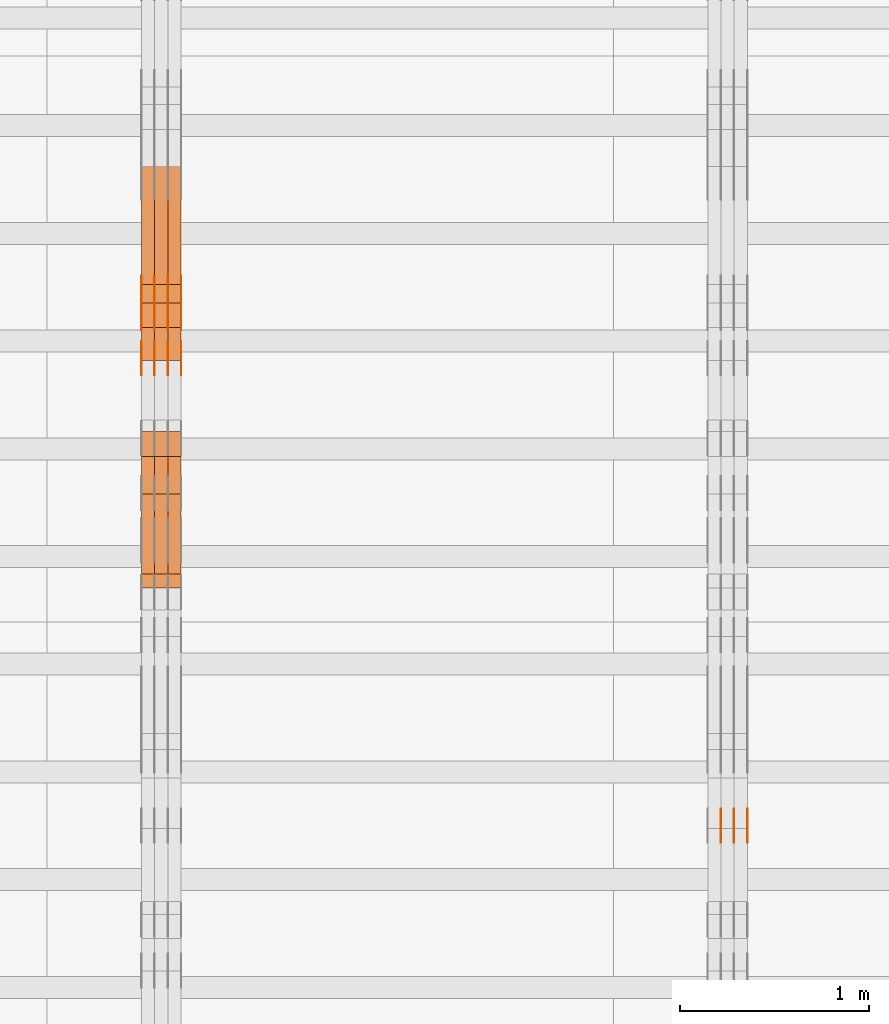
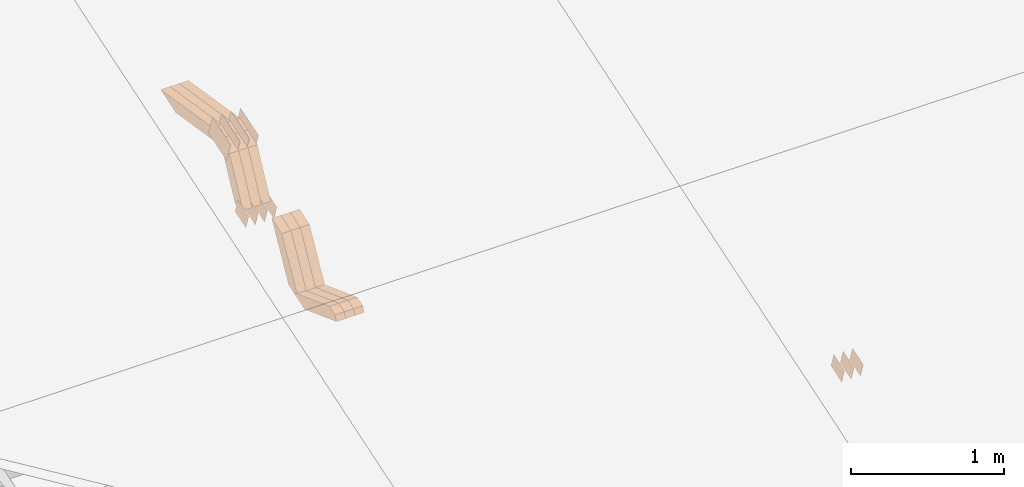
# One storey, part 66 of 385: 28 proxies.
"""IFC2X3 building model written with IfcOpenShell, lengths in millimetres."""

from ifc_helpers import new_model, entity, si_unit, converted_unit, derived_unit, direction, frame, origin, place, context, subcontext, project, spatial, polyline, outline, extrude, source, transform, mapped, material, type_object, type_shapes, element, save


model = new_model("IFC2X3")

# Units and contexts
model_context = context("Model", 3, precision=0.01, world=origin(), true_north=direction((6.12303176911189e-17, 1.0)))
body_context = subcontext(model_context, "Body", "Model", "MODEL_VIEW")
ifc_project = project(units=[si_unit("LENGTHUNIT", "METRE", prefix="MILLI"), si_unit("AREAUNIT", "SQUARE_METRE"), si_unit("VOLUMEUNIT", "CUBIC_METRE"), converted_unit("PLANEANGLEUNIT", "DEGREE", entity("IfcRatioMeasure", 0.0174532925199433), si_unit("PLANEANGLEUNIT", "RADIAN"), dimensions=[0, 0, 0, 0, 0, 0, 0]), si_unit("MASSUNIT", "GRAM", prefix="KILO"), derived_unit("MASSDENSITYUNIT", [(si_unit("MASSUNIT", "GRAM", prefix="KILO"), 1), (si_unit("LENGTHUNIT", "METRE"), -3)]), si_unit("TIMEUNIT", "SECOND"), si_unit("FREQUENCYUNIT", "HERTZ"), si_unit("THERMODYNAMICTEMPERATUREUNIT", "DEGREE_CELSIUS"), derived_unit("THERMALTRANSMITTANCEUNIT", [(si_unit("MASSUNIT", "GRAM", prefix="KILO"), 1), (si_unit("THERMODYNAMICTEMPERATUREUNIT", "KELVIN"), -1), (si_unit("TIMEUNIT", "SECOND"), -3)]), derived_unit("VOLUMETRICFLOWRATEUNIT", [(si_unit("LENGTHUNIT", "METRE"), 3), (si_unit("TIMEUNIT", "SECOND"), -1)]), si_unit("ELECTRICCURRENTUNIT", "AMPERE"), si_unit("ELECTRICVOLTAGEUNIT", "VOLT"), si_unit("POWERUNIT", "WATT"), si_unit("FORCEUNIT", "NEWTON", prefix="KILO"), si_unit("ILLUMINANCEUNIT", "LUX"), si_unit("LUMINOUSFLUXUNIT", "LUMEN"), si_unit("LUMINOUSINTENSITYUNIT", "CANDELA"), derived_unit("USERDEFINED", [(si_unit("MASSUNIT", "GRAM", prefix="KILO"), -1), (si_unit("LENGTHUNIT", "METRE"), -2), (si_unit("TIMEUNIT", "SECOND"), 3), (si_unit("LUMINOUSFLUXUNIT", "LUMEN"), 1)]), derived_unit("LINEARVELOCITYUNIT", [(si_unit("LENGTHUNIT", "METRE"), 1), (si_unit("TIMEUNIT", "SECOND"), -1)]), si_unit("PRESSUREUNIT", "PASCAL"), derived_unit("USERDEFINED", [(si_unit("LENGTHUNIT", "METRE"), -2), (si_unit("MASSUNIT", "GRAM", prefix="KILO"), 1), (si_unit("TIMEUNIT", "SECOND"), -2)])], contexts=[model_context])

# Site, building, storey
site_placement = place(None, origin())
site = spatial("IfcSite", under=ifc_project, at=site_placement, CompositionType="ELEMENT")
building_placement = place(site_placement, origin())
building = spatial("IfcBuilding", under=site, at=building_placement, CompositionType="ELEMENT")
storey_placement = place(building_placement, origin())
storey = spatial("IfcBuildingStorey", under=building, at=storey_placement, Name="Default", CompositionType="ELEMENT", Elevation=0.0)

# Proxies
ifc_material_1 = material(Name="IfcSurfaceStyle #173340")
building_element_proxy_type_1 = type_object("IfcBuildingElementProxyType", PredefinedType="NOTDEFINED", material=ifc_material_1)
shared_shape_1 = source(origin(), body_context, "Body", "SweptSolid", [
    extrude(outline(polyline([(-74.9998565677169, -60.0000596852269), (74.9998794200137, -60.0000596852269), (74.9998565677151, 60.0000596852269), (-74.9998794200119, 60.0000596852269), (-74.9998565677169, -60.0000596852269)])), frame((74.9998794200137, 60.0000596852269, 0.0), z_axis=(0.0, 0.0, 1.0), x_axis=(-1.0, 0.0, 0.0)), (0.0, 0.0, 1.0), 1.3),
])
type_shapes(building_element_proxy_type_1, [shared_shape_1])
proxy_1_placement = place(building_placement, frame((12386.3, 7527.6269081625, 1621.97418552253), z_axis=(-1.0, 0.0, 0.0), x_axis=(0.0, 0.951056516295124, 0.309016994375039)))
element("IfcBuildingElementProxy", 1, at=proxy_1_placement, inside=storey, type_object=building_element_proxy_type_1, material=ifc_material_1, context=body_context, shape_type="MappedRepresentation", body=[
    mapped(shared_shape_1, transform((0.0, 0.0, 0.0), scale=1.0)),
])
ifc_material_2 = material(Name="IfcSurfaceStyle #173283")
building_element_proxy_type_2 = type_object("IfcBuildingElementProxyType", PredefinedType="NOTDEFINED", material=ifc_material_2)
shared_shape_2 = source(origin(), body_context, "Body", "SweptSolid", [
    extrude(outline(polyline([(-74.9998565677169, -60.0000596852269), (74.9998794200137, -60.0000596852269), (74.9998565677151, 60.0000596852269), (-74.9998794200119, 60.0000596852269), (-74.9998565677169, -60.0000596852269)])), frame((74.9998794200137, 60.0000596852269, 0.0), z_axis=(0.0, 0.0, 1.0), x_axis=(-1.0, 0.0, 0.0)), (0.0, 0.0, 1.0), 1.3),
])
type_shapes(building_element_proxy_type_2, [shared_shape_2])
proxy_2_placement = place(building_placement, frame((12315.0, 7527.6269081625, 1621.97418552253), z_axis=(-1.0, 0.0, 0.0), x_axis=(0.0, 0.951056516295124, 0.309016994375039)))
element("IfcBuildingElementProxy", 2, at=proxy_2_placement, inside=storey, type_object=building_element_proxy_type_2, material=ifc_material_2, context=body_context, shape_type="MappedRepresentation", body=[
    mapped(shared_shape_2, transform((0.0, 0.0, 0.0), scale=1.0)),
])
ifc_material_3 = material(Name="IfcSurfaceStyle #173226")
building_element_proxy_type_3 = type_object("IfcBuildingElementProxyType", PredefinedType="NOTDEFINED", material=ifc_material_3)
shared_shape_3 = source(origin(), body_context, "Body", "SweptSolid", [
    extrude(outline(polyline([(-74.9998565677169, -60.0000596852269), (74.9998794200137, -60.0000596852269), (74.9998565677151, 60.0000596852269), (-74.9998794200119, 60.0000596852269), (-74.9998565677169, -60.0000596852269)])), frame((74.9998794200137, 60.0000596852269, 0.0), z_axis=(0.0, 0.0, 1.0), x_axis=(-1.0, 0.0, 0.0)), (0.0, 0.0, 1.0), 1.3),
])
type_shapes(building_element_proxy_type_3, [shared_shape_3])
proxy_3_placement = place(building_placement, frame((12316.3, 7527.6269081625, 1621.97418552253), z_axis=(-1.0, 0.0, 0.0), x_axis=(0.0, 0.951056516295124, 0.309016994375039)))
element("IfcBuildingElementProxy", 3, at=proxy_3_placement, inside=storey, type_object=building_element_proxy_type_3, material=ifc_material_3, context=body_context, shape_type="MappedRepresentation", body=[
    mapped(shared_shape_3, transform((0.0, 0.0, 0.0), scale=1.0)),
])
ifc_material_4 = material(Name="IfcSurfaceStyle #173169")
building_element_proxy_type_4 = type_object("IfcBuildingElementProxyType", PredefinedType="NOTDEFINED", material=ifc_material_4)
shared_shape_4 = source(origin(), body_context, "Body", "SweptSolid", [
    extrude(outline(polyline([(-74.9998565677169, -60.0000596852269), (74.9998794200137, -60.0000596852269), (74.9998565677151, 60.0000596852269), (-74.9998794200119, 60.0000596852269), (-74.9998565677169, -60.0000596852269)])), frame((74.9998794200137, 60.0000596852269, 0.0), z_axis=(0.0, 0.0, 1.0), x_axis=(-1.0, 0.0, 0.0)), (0.0, 0.0, 1.0), 1.29999999999999),
])
type_shapes(building_element_proxy_type_4, [shared_shape_4])
proxy_4_placement = place(building_placement, frame((12245.0, 7527.6269081625, 1621.97418552253), z_axis=(-1.0, 0.0, 0.0), x_axis=(0.0, 0.951056516295124, 0.309016994375039)))
element("IfcBuildingElementProxy", 4, at=proxy_4_placement, inside=storey, type_object=building_element_proxy_type_4, material=ifc_material_4, context=body_context, shape_type="MappedRepresentation", body=[
    mapped(shared_shape_4, transform((0.0, 0.0, 0.0), scale=1.0)),
])
ifc_material_5 = material(Name="IfcSurfaceStyle #140960")
building_element_proxy_type_5 = type_object("IfcBuildingElementProxyType", PredefinedType="NOTDEFINED", material=ifc_material_5)
shared_shape_5 = source(origin(), body_context, "Body", "SweptSolid", [
    extrude(outline(polyline([(-124.999432723313, -83.9999457831645), (125.000177551971, -83.9999457831645), (124.999395001513, 83.9999457831646), (-125.000139830171, 83.9999457831645), (-124.999432723313, -83.9999457831645)])), frame((125.000177551971, 84.0001194377192, 0.0), z_axis=(0.0, 0.0, 1.0), x_axis=(-1.0, 0.0, 0.0)), (0.0, 0.0, 1.0), 1.3),
])
type_shapes(building_element_proxy_type_5, [shared_shape_5])
proxy_5_placement = place(building_placement, frame((9386.29999999998, 10242.0968435407, 2855.88278137571), z_axis=(-1.0, 0.0, 0.0), x_axis=(0.0, 0.951056516295154, 0.309016994374948)))
element("IfcBuildingElementProxy", 5, at=proxy_5_placement, inside=storey, type_object=building_element_proxy_type_5, material=ifc_material_5, context=body_context, shape_type="MappedRepresentation", body=[
    mapped(shared_shape_5, transform((0.0, 0.0, 0.0), scale=1.0)),
])
ifc_material_6 = material(Name="IfcSurfaceStyle #140903")
building_element_proxy_type_6 = type_object("IfcBuildingElementProxyType", PredefinedType="NOTDEFINED", material=ifc_material_6)
shared_shape_6 = source(origin(), body_context, "Body", "SweptSolid", [
    extrude(outline(polyline([(-124.999432723313, -83.9999457831645), (125.000177551971, -83.9999457831645), (124.999395001513, 83.9999457831646), (-125.000139830171, 83.9999457831645), (-124.999432723313, -83.9999457831645)])), frame((125.000177551971, 84.0001194377192, 0.0), z_axis=(0.0, 0.0, 1.0), x_axis=(-1.0, 0.0, 0.0)), (0.0, 0.0, 1.0), 1.3),
])
type_shapes(building_element_proxy_type_6, [shared_shape_6])
proxy_6_placement = place(building_placement, frame((9315.0, 10242.0968435407, 2855.88278137571), z_axis=(-1.0, 0.0, 0.0), x_axis=(0.0, 0.951056516295154, 0.309016994374948)))
element("IfcBuildingElementProxy", 6, at=proxy_6_placement, inside=storey, type_object=building_element_proxy_type_6, material=ifc_material_6, context=body_context, shape_type="MappedRepresentation", body=[
    mapped(shared_shape_6, transform((0.0, 0.0, 0.0), scale=1.0)),
])
ifc_material_7 = material(Name="IfcSurfaceStyle #140846")
building_element_proxy_type_7 = type_object("IfcBuildingElementProxyType", PredefinedType="NOTDEFINED", material=ifc_material_7)
shared_shape_7 = source(origin(), body_context, "Body", "SweptSolid", [
    extrude(outline(polyline([(-124.999432723313, -83.9999457831645), (125.000177551971, -83.9999457831645), (124.999395001513, 83.9999457831646), (-125.000139830171, 83.9999457831645), (-124.999432723313, -83.9999457831645)])), frame((125.000177551971, 84.0001194377192, 0.0), z_axis=(0.0, 0.0, 1.0), x_axis=(-1.0, 0.0, 0.0)), (0.0, 0.0, 1.0), 1.3),
])
type_shapes(building_element_proxy_type_7, [shared_shape_7])
proxy_7_placement = place(building_placement, frame((9316.29999999998, 10242.0968435407, 2855.88278137571), z_axis=(-1.0, 0.0, 0.0), x_axis=(0.0, 0.951056516295154, 0.309016994374948)))
element("IfcBuildingElementProxy", 7, at=proxy_7_placement, inside=storey, type_object=building_element_proxy_type_7, material=ifc_material_7, context=body_context, shape_type="MappedRepresentation", body=[
    mapped(shared_shape_7, transform((0.0, 0.0, 0.0), scale=1.0)),
])
ifc_material_8 = material(Name="IfcSurfaceStyle #140789")
building_element_proxy_type_8 = type_object("IfcBuildingElementProxyType", PredefinedType="NOTDEFINED", material=ifc_material_8)
shared_shape_8 = source(origin(), body_context, "Body", "SweptSolid", [
    extrude(outline(polyline([(-124.999432723313, -83.9999457831645), (125.000177551971, -83.9999457831645), (124.999395001513, 83.9999457831646), (-125.000139830171, 83.9999457831645), (-124.999432723313, -83.9999457831645)])), frame((125.000177551971, 84.0001194377192, 0.0), z_axis=(0.0, 0.0, 1.0), x_axis=(-1.0, 0.0, 0.0)), (0.0, 0.0, 1.0), 1.29999999999998),
])
type_shapes(building_element_proxy_type_8, [shared_shape_8])
proxy_8_placement = place(building_placement, frame((9245.0, 10242.0968435407, 2855.88278137571), z_axis=(-1.0, 0.0, 0.0), x_axis=(0.0, 0.951056516295154, 0.309016994374948)))
element("IfcBuildingElementProxy", 8, at=proxy_8_placement, inside=storey, type_object=building_element_proxy_type_8, material=ifc_material_8, context=body_context, shape_type="MappedRepresentation", body=[
    mapped(shared_shape_8, transform((0.0, 0.0, 0.0), scale=1.0)),
])
ifc_material_9 = material(Name="IfcSurfaceStyle #140732")
building_element_proxy_type_9 = type_object("IfcBuildingElementProxyType", PredefinedType="NOTDEFINED", material=ifc_material_9)
shared_shape_9 = source(origin(), body_context, "Body", "SweptSolid", [
    extrude(outline(polyline([(-124.999432723313, -83.9999457831645), (125.000177551971, -83.9999457831645), (124.999395001513, 83.9999457831646), (-125.000139830171, 83.9999457831645), (-124.999432723313, -83.9999457831645)])), frame((125.000177551971, 84.0001194377192, 0.0), z_axis=(0.0, 0.0, 1.0), x_axis=(-1.0, 0.0, 0.0)), (0.0, 0.0, 1.0), 1.29999999999998),
])
type_shapes(building_element_proxy_type_9, [shared_shape_9])
proxy_9_placement = place(building_placement, frame((9246.29999999998, 10242.0968435407, 2855.88278137571), z_axis=(-1.0, 0.0, 0.0), x_axis=(0.0, 0.951056516295154, 0.309016994374948)))
element("IfcBuildingElementProxy", 9, at=proxy_9_placement, inside=storey, type_object=building_element_proxy_type_9, material=ifc_material_9, context=body_context, shape_type="MappedRepresentation", body=[
    mapped(shared_shape_9, transform((0.0, 0.0, 0.0), scale=1.0)),
])
ifc_material_10 = material(Name="IfcSurfaceStyle #140675")
building_element_proxy_type_10 = type_object("IfcBuildingElementProxyType", PredefinedType="NOTDEFINED", material=ifc_material_10)
shared_shape_10 = source(origin(), body_context, "Body", "SweptSolid", [
    extrude(outline(polyline([(-124.999432723313, -83.9999457831645), (125.000177551971, -83.9999457831645), (124.999395001513, 83.9999457831646), (-125.000139830171, 83.9999457831645), (-124.999432723313, -83.9999457831645)])), frame((125.000177551971, 84.0001194377192, 0.0), z_axis=(0.0, 0.0, 1.0), x_axis=(-1.0, 0.0, 0.0)), (0.0, 0.0, 1.0), 1.29999999999998),
])
type_shapes(building_element_proxy_type_10, [shared_shape_10])
proxy_10_placement = place(building_placement, frame((9175.0, 10242.0968435407, 2855.88278137571), z_axis=(-1.0, 0.0, 0.0), x_axis=(0.0, 0.951056516295154, 0.309016994374948)))
element("IfcBuildingElementProxy", 10, at=proxy_10_placement, inside=storey, type_object=building_element_proxy_type_10, material=ifc_material_10, context=body_context, shape_type="MappedRepresentation", body=[
    mapped(shared_shape_10, transform((0.0, 0.0, 0.0), scale=1.0)),
])
ifc_material_11 = material(Name="IfcSurfaceStyle #139250")
building_element_proxy_type_11 = type_object("IfcBuildingElementProxyType", PredefinedType="NOTDEFINED", material=ifc_material_11)
shared_shape_11 = source(origin(), body_context, "Body", "SweptSolid", [
    extrude(outline(polyline([(-74.9998754286189, -60.0000016373433), (74.9998605591118, -60.0000016373433), (74.9998754286189, 60.0000016373433), (-74.9998605591118, 60.0000016373433), (-74.9998754286189, -60.0000016373433)])), frame((74.9999131819004, 60.0000016373433, 0.0), z_axis=(0.0, 0.0, 1.0), x_axis=(-1.0, 0.0, 0.0)), (0.0, 0.0, 1.0), 1.3),
])
type_shapes(building_element_proxy_type_11, [shared_shape_11])
proxy_11_placement = place(building_placement, frame((9386.29999999998, 10004.8612689908, 2426.87628052724), z_axis=(-1.0, 0.0, 0.0), x_axis=(0.0, 0.951056516295124, 0.309016994375039)))
element("IfcBuildingElementProxy", 11, at=proxy_11_placement, inside=storey, type_object=building_element_proxy_type_11, material=ifc_material_11, context=body_context, shape_type="MappedRepresentation", body=[
    mapped(shared_shape_11, transform((0.0, 0.0, 0.0), scale=1.0)),
])
ifc_material_12 = material(Name="IfcSurfaceStyle #139193")
building_element_proxy_type_12 = type_object("IfcBuildingElementProxyType", PredefinedType="NOTDEFINED", material=ifc_material_12)
shared_shape_12 = source(origin(), body_context, "Body", "SweptSolid", [
    extrude(outline(polyline([(-74.9998754286189, -60.0000016373433), (74.9998605591118, -60.0000016373433), (74.9998754286189, 60.0000016373433), (-74.9998605591118, 60.0000016373433), (-74.9998754286189, -60.0000016373433)])), frame((74.9999131819004, 60.0000016373433, 0.0), z_axis=(0.0, 0.0, 1.0), x_axis=(-1.0, 0.0, 0.0)), (0.0, 0.0, 1.0), 1.3),
])
type_shapes(building_element_proxy_type_12, [shared_shape_12])
proxy_12_placement = place(building_placement, frame((9315.0, 10004.8612689908, 2426.87628052724), z_axis=(-1.0, 0.0, 0.0), x_axis=(0.0, 0.951056516295124, 0.309016994375039)))
element("IfcBuildingElementProxy", 12, at=proxy_12_placement, inside=storey, type_object=building_element_proxy_type_12, material=ifc_material_12, context=body_context, shape_type="MappedRepresentation", body=[
    mapped(shared_shape_12, transform((0.0, 0.0, 0.0), scale=1.0)),
])
ifc_material_13 = material(Name="IfcSurfaceStyle #139136")
building_element_proxy_type_13 = type_object("IfcBuildingElementProxyType", PredefinedType="NOTDEFINED", material=ifc_material_13)
shared_shape_13 = source(origin(), body_context, "Body", "SweptSolid", [
    extrude(outline(polyline([(-74.9998754286189, -60.0000016373433), (74.9998605591118, -60.0000016373433), (74.9998754286189, 60.0000016373433), (-74.9998605591118, 60.0000016373433), (-74.9998754286189, -60.0000016373433)])), frame((74.9999131819004, 60.0000016373433, 0.0), z_axis=(0.0, 0.0, 1.0), x_axis=(-1.0, 0.0, 0.0)), (0.0, 0.0, 1.0), 1.3),
])
type_shapes(building_element_proxy_type_13, [shared_shape_13])
proxy_13_placement = place(building_placement, frame((9316.29999999998, 10004.8612689908, 2426.87628052724), z_axis=(-1.0, 0.0, 0.0), x_axis=(0.0, 0.951056516295124, 0.309016994375039)))
element("IfcBuildingElementProxy", 13, at=proxy_13_placement, inside=storey, type_object=building_element_proxy_type_13, material=ifc_material_13, context=body_context, shape_type="MappedRepresentation", body=[
    mapped(shared_shape_13, transform((0.0, 0.0, 0.0), scale=1.0)),
])
ifc_material_14 = material(Name="IfcSurfaceStyle #139079")
building_element_proxy_type_14 = type_object("IfcBuildingElementProxyType", PredefinedType="NOTDEFINED", material=ifc_material_14)
shared_shape_14 = source(origin(), body_context, "Body", "SweptSolid", [
    extrude(outline(polyline([(-74.9998754286189, -60.0000016373433), (74.9998605591118, -60.0000016373433), (74.9998754286189, 60.0000016373433), (-74.9998605591118, 60.0000016373433), (-74.9998754286189, -60.0000016373433)])), frame((74.9999131819004, 60.0000016373433, 0.0), z_axis=(0.0, 0.0, 1.0), x_axis=(-1.0, 0.0, 0.0)), (0.0, 0.0, 1.0), 1.29999999999999),
])
type_shapes(building_element_proxy_type_14, [shared_shape_14])
proxy_14_placement = place(building_placement, frame((9245.0, 10004.8612689908, 2426.87628052724), z_axis=(-1.0, 0.0, 0.0), x_axis=(0.0, 0.951056516295124, 0.309016994375039)))
element("IfcBuildingElementProxy", 14, at=proxy_14_placement, inside=storey, type_object=building_element_proxy_type_14, material=ifc_material_14, context=body_context, shape_type="MappedRepresentation", body=[
    mapped(shared_shape_14, transform((0.0, 0.0, 0.0), scale=1.0)),
])
ifc_material_15 = material(Name="IfcSurfaceStyle #139022")
building_element_proxy_type_15 = type_object("IfcBuildingElementProxyType", PredefinedType="NOTDEFINED", material=ifc_material_15)
shared_shape_15 = source(origin(), body_context, "Body", "SweptSolid", [
    extrude(outline(polyline([(-74.9998754286189, -60.0000016373433), (74.9998605591118, -60.0000016373433), (74.9998754286189, 60.0000016373433), (-74.9998605591118, 60.0000016373433), (-74.9998754286189, -60.0000016373433)])), frame((74.9999131819004, 60.0000016373433, 0.0), z_axis=(0.0, 0.0, 1.0), x_axis=(-1.0, 0.0, 0.0)), (0.0, 0.0, 1.0), 1.29999999999999),
])
type_shapes(building_element_proxy_type_15, [shared_shape_15])
proxy_15_placement = place(building_placement, frame((9246.29999999998, 10004.8612689908, 2426.87628052724), z_axis=(-1.0, 0.0, 0.0), x_axis=(0.0, 0.951056516295124, 0.309016994375039)))
element("IfcBuildingElementProxy", 15, at=proxy_15_placement, inside=storey, type_object=building_element_proxy_type_15, material=ifc_material_15, context=body_context, shape_type="MappedRepresentation", body=[
    mapped(shared_shape_15, transform((0.0, 0.0, 0.0), scale=1.0)),
])
ifc_material_16 = material(Name="IfcSurfaceStyle #138965")
building_element_proxy_type_16 = type_object("IfcBuildingElementProxyType", PredefinedType="NOTDEFINED", material=ifc_material_16)
shared_shape_16 = source(origin(), body_context, "Body", "SweptSolid", [
    extrude(outline(polyline([(-74.9998754286189, -60.0000016373433), (74.9998605591118, -60.0000016373433), (74.9998754286189, 60.0000016373433), (-74.9998605591118, 60.0000016373433), (-74.9998754286189, -60.0000016373433)])), frame((74.9999131819004, 60.0000016373433, 0.0), z_axis=(0.0, 0.0, 1.0), x_axis=(-1.0, 0.0, 0.0)), (0.0, 0.0, 1.0), 1.29999999999999),
])
type_shapes(building_element_proxy_type_16, [shared_shape_16])
proxy_16_placement = place(building_placement, frame((9175.0, 10004.8612689908, 2426.87628052724), z_axis=(-1.0, 0.0, 0.0), x_axis=(0.0, 0.951056516295124, 0.309016994375039)))
element("IfcBuildingElementProxy", 16, at=proxy_16_placement, inside=storey, type_object=building_element_proxy_type_16, material=ifc_material_16, context=body_context, shape_type="MappedRepresentation", body=[
    mapped(shared_shape_16, transform((0.0, 0.0, 0.0), scale=1.0)),
])
ifc_material_17 = material(Name="IfcSurfaceStyle #118928")
building_element_proxy_type_17 = type_object("IfcBuildingElementProxyType", Name="T1-W5 118926", PredefinedType="NOTDEFINED", material=ifc_material_17)
shared_shape_17 = source(origin(), body_context, "Body", "SweptSolid", [
    extrude(outline(polyline([(-301.214270081322, -47.5000783565111), (303.980395954293, -47.5000783565111), (288.664123931657, 0.000197935560590153), (195.704076557203, 47.4999793887309), (-487.134326361831, 47.4999793887309), (-301.214270081322, -47.5000783565111)])), frame((303.980395954293, 47.5001815410909, 0.0), z_axis=(0.0, 0.0, 1.0), x_axis=(-1.0, 0.0, 0.0)), (0.0, 0.0, 1.0), 70.0),
])
type_shapes(building_element_proxy_type_17, [shared_shape_17])
proxy_17_placement = place(building_placement, frame((9385.0, 10379.2051671398, 2863.91176079486), z_axis=(-1.0, 0.0, 0.0), x_axis=(0.0, 0.987508363398486, -0.1575665961365)))
element("IfcBuildingElementProxy", 17, at=proxy_17_placement, inside=storey, type_object=building_element_proxy_type_17, material=ifc_material_17, Name="T1-W5", context=body_context, shape_type="MappedRepresentation", body=[
    mapped(shared_shape_17, transform((0.0, 0.0, 0.0), scale=1.0)),
])
ifc_material_18 = material(Name="IfcSurfaceStyle #118862")
building_element_proxy_type_18 = type_object("IfcBuildingElementProxyType", Name="T1-W5 118860", PredefinedType="NOTDEFINED", material=ifc_material_18)
shared_shape_18 = source(origin(), body_context, "Body", "SweptSolid", [
    extrude(outline(polyline([(-301.214270081322, -47.5000783565111), (303.980395954293, -47.5000783565111), (288.664123931657, 0.000197935560590153), (195.704076557203, 47.4999793887309), (-487.134326361831, 47.4999793887309), (-301.214270081322, -47.5000783565111)])), frame((303.980395954293, 47.5001815410909, 0.0), z_axis=(0.0, 0.0, 1.0), x_axis=(-1.0, 0.0, 0.0)), (0.0, 0.0, 1.0), 70.0),
])
type_shapes(building_element_proxy_type_18, [shared_shape_18])
proxy_18_placement = place(building_placement, frame((9315.0, 10379.2051671398, 2863.91176079486), z_axis=(-1.0, 0.0, 0.0), x_axis=(0.0, 0.987508363398486, -0.1575665961365)))
element("IfcBuildingElementProxy", 18, at=proxy_18_placement, inside=storey, type_object=building_element_proxy_type_18, material=ifc_material_18, Name="T1-W5", context=body_context, shape_type="MappedRepresentation", body=[
    mapped(shared_shape_18, transform((0.0, 0.0, 0.0), scale=1.0)),
])
ifc_material_19 = material(Name="IfcSurfaceStyle #118796")
building_element_proxy_type_19 = type_object("IfcBuildingElementProxyType", Name="T1-W5 118794", PredefinedType="NOTDEFINED", material=ifc_material_19)
shared_shape_19 = source(origin(), body_context, "Body", "SweptSolid", [
    extrude(outline(polyline([(-301.214270081322, -47.5000783565111), (303.980395954293, -47.5000783565111), (288.664123931657, 0.000197935560590153), (195.704076557203, 47.4999793887309), (-487.134326361831, 47.4999793887309), (-301.214270081322, -47.5000783565111)])), frame((303.980395954293, 47.5001815410909, 0.0), z_axis=(0.0, 0.0, 1.0), x_axis=(-1.0, 0.0, 0.0)), (0.0, 0.0, 1.0), 70.0),
])
type_shapes(building_element_proxy_type_19, [shared_shape_19])
proxy_19_placement = place(building_placement, frame((9245.0, 10379.2051671398, 2863.91176079486), z_axis=(-1.0, 0.0, 0.0), x_axis=(0.0, 0.987508363398486, -0.1575665961365)))
element("IfcBuildingElementProxy", 19, at=proxy_19_placement, inside=storey, type_object=building_element_proxy_type_19, material=ifc_material_19, Name="T1-W5", context=body_context, shape_type="MappedRepresentation", body=[
    mapped(shared_shape_19, transform((0.0, 0.0, 0.0), scale=1.0)),
])
ifc_material_20 = material(Name="IfcSurfaceStyle #118532")
building_element_proxy_type_20 = type_object("IfcBuildingElementProxyType", Name="T1-W37 118530", PredefinedType="NOTDEFINED", material=ifc_material_20)
shared_shape_20 = source(origin(), body_context, "Body", "SweptSolid", [
    extrude(outline(polyline([(111.787482004227, -179.289397746839), (245.990585035629, -179.289397746839), (-64.0177573255029, 131.410401861866), (-131.116409377007, 131.410958895698), (-162.643900337347, 95.757434736113), (111.787482004227, -179.289397746839)])), frame((185.635323570343, 47.5011799885346, 0.0), z_axis=(0.0, 0.0, 1.0), x_axis=(0.706316677358935, 0.707896003156279, 0.0)), (0.0, 0.0, 1.0), 70.0),
])
type_shapes(building_element_proxy_type_20, [shared_shape_20])
proxy_20_placement = place(building_placement, frame((9385.0, 10081.8581176196, 2424.08390440728), z_axis=(-1.0, 0.0, 0.0), x_axis=(0.0, 0.452995827831714, 0.891512635898707)))
element("IfcBuildingElementProxy", 20, at=proxy_20_placement, inside=storey, type_object=building_element_proxy_type_20, material=ifc_material_20, Name="T1-W37", context=body_context, shape_type="MappedRepresentation", body=[
    mapped(shared_shape_20, transform((0.0, 0.0, 0.0), scale=1.0)),
])
ifc_material_21 = material(Name="IfcSurfaceStyle #118466")
building_element_proxy_type_21 = type_object("IfcBuildingElementProxyType", Name="T1-W37 118464", PredefinedType="NOTDEFINED", material=ifc_material_21)
shared_shape_21 = source(origin(), body_context, "Body", "SweptSolid", [
    extrude(outline(polyline([(111.787482004227, -179.289397746839), (245.990585035629, -179.289397746839), (-64.0177573255029, 131.410401861866), (-131.116409377007, 131.410958895698), (-162.643900337347, 95.757434736113), (111.787482004227, -179.289397746839)])), frame((185.635323570343, 47.5011799885346, 0.0), z_axis=(0.0, 0.0, 1.0), x_axis=(0.706316677358935, 0.707896003156279, 0.0)), (0.0, 0.0, 1.0), 70.0),
])
type_shapes(building_element_proxy_type_21, [shared_shape_21])
proxy_21_placement = place(building_placement, frame((9315.0, 10081.8581176196, 2424.08390440728), z_axis=(-1.0, 0.0, 0.0), x_axis=(0.0, 0.452995827831714, 0.891512635898707)))
element("IfcBuildingElementProxy", 21, at=proxy_21_placement, inside=storey, type_object=building_element_proxy_type_21, material=ifc_material_21, Name="T1-W37", context=body_context, shape_type="MappedRepresentation", body=[
    mapped(shared_shape_21, transform((0.0, 0.0, 0.0), scale=1.0)),
])
ifc_material_22 = material(Name="IfcSurfaceStyle #118400")
building_element_proxy_type_22 = type_object("IfcBuildingElementProxyType", Name="T1-W37 118398", PredefinedType="NOTDEFINED", material=ifc_material_22)
shared_shape_22 = source(origin(), body_context, "Body", "SweptSolid", [
    extrude(outline(polyline([(111.787482004227, -179.289397746839), (245.990585035629, -179.289397746839), (-64.0177573255029, 131.410401861866), (-131.116409377007, 131.410958895698), (-162.643900337347, 95.757434736113), (111.787482004227, -179.289397746839)])), frame((185.635323570343, 47.5011799885346, 0.0), z_axis=(0.0, 0.0, 1.0), x_axis=(0.706316677358935, 0.707896003156279, 0.0)), (0.0, 0.0, 1.0), 70.0),
])
type_shapes(building_element_proxy_type_22, [shared_shape_22])
proxy_22_placement = place(building_placement, frame((9245.0, 10081.8581176196, 2424.08390440728), z_axis=(-1.0, 0.0, 0.0), x_axis=(0.0, 0.452995827831714, 0.891512635898707)))
element("IfcBuildingElementProxy", 22, at=proxy_22_placement, inside=storey, type_object=building_element_proxy_type_22, material=ifc_material_22, Name="T1-W37", context=body_context, shape_type="MappedRepresentation", body=[
    mapped(shared_shape_22, transform((0.0, 0.0, 0.0), scale=1.0)),
])
ifc_material_23 = material(Name="IfcSurfaceStyle #117740")
building_element_proxy_type_23 = type_object("IfcBuildingElementProxyType", Name="T1-W33 117738", PredefinedType="NOTDEFINED", material=ifc_material_23)
shared_shape_23 = source(origin(), body_context, "Body", "SweptSolid", [
    extrude(outline(polyline([(-314.173070820175, -47.4997758466969), (139.635944117881, -47.4997758466969), (190.204920608233, 0.000348187720347082), (197.369205310989, 47.5001702328475), (-213.036999216928, 47.4990332728259), (-314.173070820175, -47.4997758466969)])), frame((197.369205310989, 47.5001702328475, 0.0), z_axis=(0.0, 0.0, 1.0), x_axis=(-1.0, 0.0, 0.0)), (0.0, 0.0, 1.0), 70.0),
])
type_shapes(building_element_proxy_type_23, [shared_shape_23])
proxy_23_placement = place(building_placement, frame((9385.0, 9376.96875, 2191.01977539063), z_axis=(-1.0, 0.0, 0.0), x_axis=(0.0, 0.481632628948835, 0.876373214293907)))
element("IfcBuildingElementProxy", 23, at=proxy_23_placement, inside=storey, type_object=building_element_proxy_type_23, material=ifc_material_23, Name="T1-W33", context=body_context, shape_type="MappedRepresentation", body=[
    mapped(shared_shape_23, transform((0.0, 0.0, 0.0), scale=1.0)),
])
ifc_material_24 = material(Name="IfcSurfaceStyle #117674")
building_element_proxy_type_24 = type_object("IfcBuildingElementProxyType", Name="T1-W33 117672", PredefinedType="NOTDEFINED", material=ifc_material_24)
shared_shape_24 = source(origin(), body_context, "Body", "SweptSolid", [
    extrude(outline(polyline([(-314.173070820175, -47.4997758466969), (139.635944117881, -47.4997758466969), (190.204920608233, 0.000348187720347082), (197.369205310989, 47.5001702328475), (-213.036999216928, 47.4990332728259), (-314.173070820175, -47.4997758466969)])), frame((197.369205310989, 47.5001702328475, 0.0), z_axis=(0.0, 0.0, 1.0), x_axis=(-1.0, 0.0, 0.0)), (0.0, 0.0, 1.0), 70.0),
])
type_shapes(building_element_proxy_type_24, [shared_shape_24])
proxy_24_placement = place(building_placement, frame((9315.0, 9376.96875, 2191.01977539063), z_axis=(-1.0, 0.0, 0.0), x_axis=(0.0, 0.481632628948835, 0.876373214293907)))
element("IfcBuildingElementProxy", 24, at=proxy_24_placement, inside=storey, type_object=building_element_proxy_type_24, material=ifc_material_24, Name="T1-W33", context=body_context, shape_type="MappedRepresentation", body=[
    mapped(shared_shape_24, transform((0.0, 0.0, 0.0), scale=1.0)),
])
ifc_material_25 = material(Name="IfcSurfaceStyle #117608")
building_element_proxy_type_25 = type_object("IfcBuildingElementProxyType", Name="T1-W33 117606", PredefinedType="NOTDEFINED", material=ifc_material_25)
shared_shape_25 = source(origin(), body_context, "Body", "SweptSolid", [
    extrude(outline(polyline([(-314.173070820175, -47.4997758466969), (139.635944117881, -47.4997758466969), (190.204920608233, 0.000348187720347082), (197.369205310989, 47.5001702328475), (-213.036999216928, 47.4990332728259), (-314.173070820175, -47.4997758466969)])), frame((197.369205310989, 47.5001702328475, 0.0), z_axis=(0.0, 0.0, 1.0), x_axis=(-1.0, 0.0, 0.0)), (0.0, 0.0, 1.0), 70.0),
])
type_shapes(building_element_proxy_type_25, [shared_shape_25])
proxy_25_placement = place(building_placement, frame((9245.0, 9376.96875, 2191.01977539063), z_axis=(-1.0, 0.0, 0.0), x_axis=(0.0, 0.481632628948835, 0.876373214293907)))
element("IfcBuildingElementProxy", 25, at=proxy_25_placement, inside=storey, type_object=building_element_proxy_type_25, material=ifc_material_25, Name="T1-W33", context=body_context, shape_type="MappedRepresentation", body=[
    mapped(shared_shape_25, transform((0.0, 0.0, 0.0), scale=1.0)),
])
ifc_material_26 = material(Name="IfcSurfaceStyle #117344")
building_element_proxy_type_26 = type_object("IfcBuildingElementProxyType", Name="T1-W25 117342", PredefinedType="NOTDEFINED", material=ifc_material_26)
shared_shape_26 = source(origin(), body_context, "Body", "SweptSolid", [
    extrude(outline(polyline([(-229.232772462784, -47.5001671709529), (214.075939394384, -47.5001671709529), (212.688957821661, -0.000141058964427199), (152.358910178478, 47.5002377004352), (-349.891034931738, 47.5002377004352), (-229.232772462784, -47.5001671709529)])), frame((214.075939394384, 47.5002377004352, 0.0), z_axis=(0.0, 0.0, 1.0), x_axis=(-1.0, 0.0, 0.0)), (0.0, 0.0, 1.0), 70.0),
])
type_shapes(building_element_proxy_type_26, [shared_shape_26])
proxy_26_placement = place(building_placement, frame((9385.0, 8892.81895960242, 2369.29665807578), z_axis=(-1.0, 0.0, 0.0), x_axis=(0.0, 0.938402514401222, -0.345544094097213)))
element("IfcBuildingElementProxy", 26, at=proxy_26_placement, inside=storey, type_object=building_element_proxy_type_26, material=ifc_material_26, Name="T1-W25", context=body_context, shape_type="MappedRepresentation", body=[
    mapped(shared_shape_26, transform((0.0, 0.0, 0.0), scale=1.0)),
])
ifc_material_27 = material(Name="IfcSurfaceStyle #117278")
building_element_proxy_type_27 = type_object("IfcBuildingElementProxyType", Name="T1-W25 117276", PredefinedType="NOTDEFINED", material=ifc_material_27)
shared_shape_27 = source(origin(), body_context, "Body", "SweptSolid", [
    extrude(outline(polyline([(-229.232772462784, -47.5001671709529), (214.075939394384, -47.5001671709529), (212.688957821661, -0.000141058964427199), (152.358910178478, 47.5002377004352), (-349.891034931738, 47.5002377004352), (-229.232772462784, -47.5001671709529)])), frame((214.075939394384, 47.5002377004352, 0.0), z_axis=(0.0, 0.0, 1.0), x_axis=(-1.0, 0.0, 0.0)), (0.0, 0.0, 1.0), 70.0),
])
type_shapes(building_element_proxy_type_27, [shared_shape_27])
proxy_27_placement = place(building_placement, frame((9315.0, 8892.81895960242, 2369.29665807578), z_axis=(-1.0, 0.0, 0.0), x_axis=(0.0, 0.938402514401222, -0.345544094097213)))
element("IfcBuildingElementProxy", 27, at=proxy_27_placement, inside=storey, type_object=building_element_proxy_type_27, material=ifc_material_27, Name="T1-W25", context=body_context, shape_type="MappedRepresentation", body=[
    mapped(shared_shape_27, transform((0.0, 0.0, 0.0), scale=1.0)),
])
ifc_material_28 = material(Name="IfcSurfaceStyle #117212")
building_element_proxy_type_28 = type_object("IfcBuildingElementProxyType", Name="T1-W25 117210", PredefinedType="NOTDEFINED", material=ifc_material_28)
shared_shape_28 = source(origin(), body_context, "Body", "SweptSolid", [
    extrude(outline(polyline([(-229.232772462784, -47.5001671709529), (214.075939394384, -47.5001671709529), (212.688957821661, -0.000141058964427199), (152.358910178478, 47.5002377004352), (-349.891034931738, 47.5002377004352), (-229.232772462784, -47.5001671709529)])), frame((214.075939394384, 47.5002377004352, 0.0), z_axis=(0.0, 0.0, 1.0), x_axis=(-1.0, 0.0, 0.0)), (0.0, 0.0, 1.0), 70.0),
])
type_shapes(building_element_proxy_type_28, [shared_shape_28])
proxy_28_placement = place(building_placement, frame((9245.0, 8892.81895960242, 2369.29665807578), z_axis=(-1.0, 0.0, 0.0), x_axis=(0.0, 0.938402514401222, -0.345544094097213)))
element("IfcBuildingElementProxy", 28, at=proxy_28_placement, inside=storey, type_object=building_element_proxy_type_28, material=ifc_material_28, Name="T1-W25", context=body_context, shape_type="MappedRepresentation", body=[
    mapped(shared_shape_28, transform((0.0, 0.0, 0.0), scale=1.0)),
])

save(model, "model.ifc")
